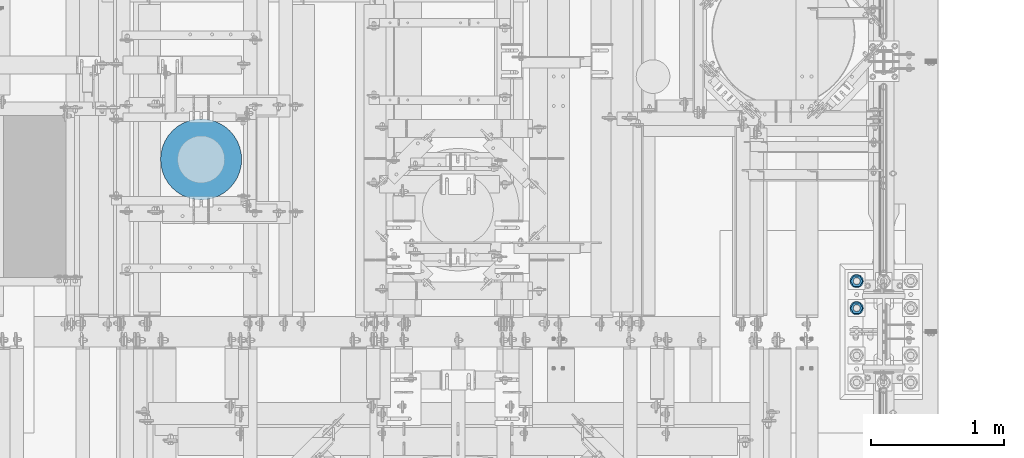
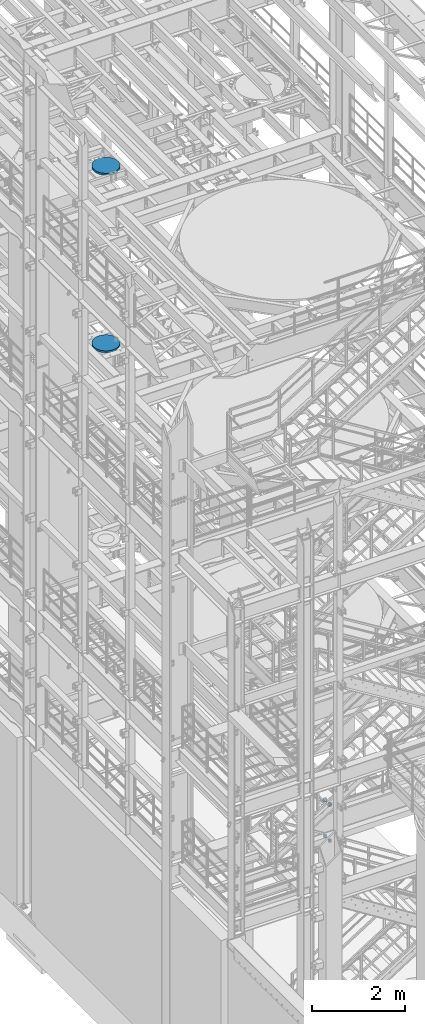
# One storey, part 839 of 1876: 8 columns, 3 elements without a shape of their own.
"""IFC2X3 building model written with IfcOpenShell, lengths in millimetres."""

from ifc_helpers import new_model, si_unit, frame, origin_with_axes, place, context, subcontext, project, spatial, faceted_brep, material, type_object, element, aggregate, save


model = new_model("IFC2X3")

# Units and contexts
model_context = context("Model", 3, precision=1e-05, world=origin_with_axes())
body_context = subcontext(model_context, "Body", "Model", "MODEL_VIEW")
ifc_project = project(units=[si_unit("LENGTHUNIT", "METRE", prefix="MILLI"), si_unit("AREAUNIT", "SQUARE_METRE"), si_unit("VOLUMEUNIT", "CUBIC_METRE"), si_unit("MASSUNIT", "GRAM", prefix="KILO"), si_unit("TIMEUNIT", "SECOND"), si_unit("PLANEANGLEUNIT", "RADIAN"), si_unit("SOLIDANGLEUNIT", "STERADIAN"), si_unit("THERMODYNAMICTEMPERATUREUNIT", "DEGREE_CELSIUS"), si_unit("LUMINOUSINTENSITYUNIT", "LUMEN")], contexts=[model_context])

# Site, building, storey
site_placement = place(None, origin_with_axes())
site = spatial("IfcSite", under=ifc_project, at=site_placement, CompositionType="ELEMENT")
building_placement = place(site_placement, origin_with_axes())
building = spatial("IfcBuilding", under=site, at=building_placement, Name="Undefined", CompositionType="ELEMENT")
storey_placement = place(building_placement, origin_with_axes())
storey = spatial("IfcBuildingStorey", under=building, at=storey_placement, Name="Undefined", CompositionType="ELEMENT", Elevation=0.0)

# Assembly, columns
assembly_1_placement = place(storey_placement, origin_with_axes())
assembly_1 = element("IfcElementAssembly", 1, at=assembly_1_placement, inside=storey, Name="TEMPLATE", AssemblyPlace="NOTDEFINED", PredefinedType="RIGID_FRAME")
ifc_material_1 = material(Name="STEEL/F436")
column_type_1 = type_object("IfcColumnType", Name="2_WASHER", PredefinedType="NOTDEFINED")
column_1_placement = place(assembly_1_placement, frame((7416.8, 1701.8, 119.0625), z_axis=(0.0, -1.0, 0.0), x_axis=(0.0, 0.0, -1.0)))
column_1 = element("IfcColumn", 2, at=column_1_placement, type_object=column_type_1, material=ifc_material_1, Name="WASHER", ObjectType="2_WASHER", context=body_context, shape_type="Brep", body=[
    faceted_brep([(0.0, -50.7999992370605, 9.09494701772928e-13), (0.0, -45.7692178020588, -22.0412936161442), (4.7625, -45.7692178020588, -22.0412936161442), (4.7625, -50.7999992370605, 9.09494701772928e-13), (0.0, -31.6732814587394, -39.7170387128856), (4.7625, -31.6732814587394, -39.7170387128856), (0.0, -11.3040632752118, -49.5263371950259), (4.7625, -11.3040632752118, -49.5263371950259), (0.0, 11.30406327521, -49.5263371950264), (4.7625, 11.30406327521, -49.5263371950264), (0.0, 31.6732814587385, -39.7170387128867), (4.7625, 31.6732814587385, -39.7170387128867), (0.0, 45.7692178020579, -22.041293616146), (4.7625, 45.7692178020579, -22.041293616146), (0.0, 50.7999992370605, -9.09494701772928e-13), (4.7625, 50.7999992370605, -9.09494701772928e-13), (0.0, 45.7692178020588, 22.0412936161442), (4.7625, 45.7692178020588, 22.0412936161442), (0.0, 31.6732814587394, 39.7170387128856), (4.7625, 31.6732814587394, 39.7170387128856), (0.0, 11.3040632752118, 49.5263371950259), (4.7625, 11.3040632752118, 49.5263371950259), (0.0, -11.30406327521, 49.5263371950264), (4.7625, -11.30406327521, 49.5263371950264), (0.0, -31.6732814587385, 39.7170387128867), (4.7625, -31.6732814587385, 39.7170387128867), (0.0, -45.7692178020579, 22.041293616146), (4.7625, -45.7692178020579, 22.041293616146), (0.0, 0.0, 26.9869995117188), (0.0, 11.7093983825444, 24.3146012721213), (4.7625, 11.7093983825444, 24.3146012721213), (4.7625, 0.0, 26.9869995117188), (0.0, 21.0996520289491, 16.8262864224157), (4.7625, 21.0996520289491, 16.8262864224157), (0.0, 26.3108629296712, 6.00524193584533), (4.7625, 26.3108629296712, 6.00524193584533), (0.0, 26.3108629296712, -6.00524193584533), (4.7625, 26.3108629296712, -6.00524193584533), (0.0, 21.0996520289491, -16.8262864224157), (4.7625, 21.0996520289491, -16.8262864224157), (0.0, 11.7093983825444, -24.3146012721213), (4.7625, 11.7093983825444, -24.3146012721213), (0.0, 0.0, -26.9869995117188), (4.7625, 0.0, -26.9869995117188), (0.0, -11.7093983825444, -24.3146012721213), (4.7625, -11.7093983825444, -24.3146012721213), (0.0, -21.0996520289491, -16.8262864224157), (4.7625, -21.0996520289491, -16.8262864224157), (0.0, -26.3108629296712, -6.00524193584533), (4.7625, -26.3108629296712, -6.00524193584533), (0.0, -26.3108629296712, 6.00524193584533), (4.7625, -26.3108629296712, 6.00524193584533), (0.0, -21.0996520289491, 16.8262864224157), (4.7625, -21.0996520289491, 16.8262864224157), (0.0, -11.7093983825444, 24.3146012721213), (4.7625, -11.7093983825444, 24.3146012721213)], [[[0, 1, 2, 3]], [[1, 4, 5, 2]], [[4, 6, 7, 5]], [[6, 8, 9, 7]], [[8, 10, 11, 9]], [[10, 12, 13, 11]], [[12, 14, 15, 13]], [[14, 16, 17, 15]], [[16, 18, 19, 17]], [[18, 20, 21, 19]], [[20, 22, 23, 21]], [[22, 24, 25, 23]], [[24, 26, 27, 25]], [[26, 0, 3, 27]], [[28, 29, 30, 31]], [[29, 32, 33, 30]], [[32, 34, 35, 33]], [[34, 36, 37, 35]], [[36, 38, 39, 37]], [[38, 40, 41, 39]], [[40, 42, 43, 41]], [[42, 44, 45, 43]], [[44, 46, 47, 45]], [[46, 48, 49, 47]], [[48, 50, 51, 49]], [[50, 52, 53, 51]], [[52, 54, 55, 53]], [[54, 28, 31, 55]], [[5, 7, 9, 11, 13, 15, 17, 19, 21, 23, 25, 27, 3, 2], [33, 35, 37, 39, 41, 43, 45, 47, 49, 51, 53, 55, 31, 30]], [[26, 24, 22, 20, 18, 16, 14, 12, 10, 8, 6, 4, 1, 0], [54, 52, 50, 48, 46, 44, 42, 40, 38, 36, 34, 32, 29, 28]]]),
])
column_2_placement = place(assembly_1_placement, frame((7416.8, 1905.0, 119.0625), z_axis=(0.0, -1.0, 0.0), x_axis=(0.0, 0.0, -1.0)))
column_2 = element("IfcColumn", 3, at=column_2_placement, type_object=column_type_1, material=ifc_material_1, Name="WASHER", ObjectType="2_WASHER", context=body_context, shape_type="Brep", body=[
    faceted_brep([(0.0, -50.7999992370605, 9.09494701772928e-13), (0.0, -45.7692178020588, -22.0412936161442), (4.7625, -45.7692178020588, -22.0412936161442), (4.7625, -50.7999992370605, 9.09494701772928e-13), (0.0, -31.6732814587394, -39.7170387128856), (4.7625, -31.6732814587394, -39.7170387128856), (0.0, -11.3040632752118, -49.5263371950259), (4.7625, -11.3040632752118, -49.5263371950259), (0.0, 11.30406327521, -49.5263371950264), (4.7625, 11.30406327521, -49.5263371950264), (0.0, 31.6732814587385, -39.7170387128867), (4.7625, 31.6732814587385, -39.7170387128867), (0.0, 45.7692178020579, -22.041293616146), (4.7625, 45.7692178020579, -22.041293616146), (0.0, 50.7999992370605, -9.09494701772928e-13), (4.7625, 50.7999992370605, -9.09494701772928e-13), (0.0, 45.7692178020588, 22.0412936161442), (4.7625, 45.7692178020588, 22.0412936161442), (0.0, 31.6732814587394, 39.7170387128856), (4.7625, 31.6732814587394, 39.7170387128856), (0.0, 11.3040632752118, 49.5263371950259), (4.7625, 11.3040632752118, 49.5263371950259), (0.0, -11.30406327521, 49.5263371950264), (4.7625, -11.30406327521, 49.5263371950264), (0.0, -31.6732814587385, 39.7170387128867), (4.7625, -31.6732814587385, 39.7170387128867), (0.0, -45.7692178020579, 22.041293616146), (4.7625, -45.7692178020579, 22.041293616146), (0.0, 0.0, 26.9869995117188), (0.0, 11.7093983825444, 24.3146012721213), (4.7625, 11.7093983825444, 24.3146012721213), (4.7625, 0.0, 26.9869995117188), (0.0, 21.0996520289491, 16.8262864224157), (4.7625, 21.0996520289491, 16.8262864224157), (0.0, 26.3108629296712, 6.00524193584533), (4.7625, 26.3108629296712, 6.00524193584533), (0.0, 26.3108629296712, -6.00524193584533), (4.7625, 26.3108629296712, -6.00524193584533), (0.0, 21.0996520289491, -16.8262864224157), (4.7625, 21.0996520289491, -16.8262864224157), (0.0, 11.7093983825444, -24.3146012721213), (4.7625, 11.7093983825444, -24.3146012721213), (0.0, 0.0, -26.9869995117188), (4.7625, 0.0, -26.9869995117188), (0.0, -11.7093983825444, -24.3146012721213), (4.7625, -11.7093983825444, -24.3146012721213), (0.0, -21.0996520289491, -16.8262864224157), (4.7625, -21.0996520289491, -16.8262864224157), (0.0, -26.3108629296712, -6.00524193584533), (4.7625, -26.3108629296712, -6.00524193584533), (0.0, -26.3108629296712, 6.00524193584533), (4.7625, -26.3108629296712, 6.00524193584533), (0.0, -21.0996520289491, 16.8262864224157), (4.7625, -21.0996520289491, 16.8262864224157), (0.0, -11.7093983825444, 24.3146012721213), (4.7625, -11.7093983825444, 24.3146012721213)], [[[0, 1, 2, 3]], [[1, 4, 5, 2]], [[4, 6, 7, 5]], [[6, 8, 9, 7]], [[8, 10, 11, 9]], [[10, 12, 13, 11]], [[12, 14, 15, 13]], [[14, 16, 17, 15]], [[16, 18, 19, 17]], [[18, 20, 21, 19]], [[20, 22, 23, 21]], [[22, 24, 25, 23]], [[24, 26, 27, 25]], [[26, 0, 3, 27]], [[28, 29, 30, 31]], [[29, 32, 33, 30]], [[32, 34, 35, 33]], [[34, 36, 37, 35]], [[36, 38, 39, 37]], [[38, 40, 41, 39]], [[40, 42, 43, 41]], [[42, 44, 45, 43]], [[44, 46, 47, 45]], [[46, 48, 49, 47]], [[48, 50, 51, 49]], [[50, 52, 53, 51]], [[52, 54, 55, 53]], [[54, 28, 31, 55]], [[5, 7, 9, 11, 13, 15, 17, 19, 21, 23, 25, 27, 3, 2], [33, 35, 37, 39, 41, 43, 45, 47, 49, 51, 53, 55, 31, 30]], [[26, 24, 22, 20, 18, 16, 14, 12, 10, 8, 6, 4, 1, 0], [54, 52, 50, 48, 46, 44, 42, 40, 38, 36, 34, 32, 29, 28]]]),
])

# Assembly, column
assembly_2_placement = place(storey_placement, origin_with_axes())
assembly_2 = element("IfcElementAssembly", 4, at=assembly_2_placement, inside=storey, Name="COLUMN", AssemblyPlace="NOTDEFINED", PredefinedType="REINFORCEMENT_UNIT")
ifc_material_2 = material(Name="CONCRETE/3000")
column_type_2 = type_object("IfcColumnType", PredefinedType="NOTDEFINED")
column_3_placement = place(assembly_2_placement, frame((2489.2, 2819.4, 17957.8), z_axis=(-1.0, 0.0, 0.0), x_axis=(0.0, 0.0, 1.0)))
column_3 = element("IfcColumn", 5, at=column_3_placement, type_object=column_type_2, material=ifc_material_2, Name="COLUMN", context=body_context, shape_type="Brep", body=[
    faceted_brep([(0.0, -304.8, 0.0), (0.0, -301.047406213398, -47.6812249442623), (50.7999999999993, -301.047406213398, -47.6812249442623), (50.7999999999993, -304.8, 0.0), (0.0, -289.882026166763, -94.1883798854842), (50.7999999999993, -289.882026166763, -94.1883798854842), (0.0, -271.578788572614, -138.376304320614), (50.7999999999993, -271.578788572614, -138.376304320614), (0.0, -246.588379885484, -179.156944898746), (50.7999999999993, -246.588379885484, -179.156944898746), (0.0, -215.52614690566, -215.52614690566), (50.7999999999993, -215.52614690566, -215.52614690566), (0.0, -179.156944898746, -246.588379885484), (50.7999999999993, -179.156944898746, -246.588379885484), (0.0, -138.376304320614, -271.578788572614), (50.7999999999993, -138.376304320614, -271.578788572614), (0.0, -94.1883798854838, -289.882026166763), (50.7999999999993, -94.1883798854838, -289.882026166763), (0.0, -47.6812249442623, -301.047406213398), (50.7999999999993, -47.6812249442623, -301.047406213398), (0.0, 0.0, -304.8), (50.7999999999993, 0.0, -304.8), (0.0, 47.6812249442623, -301.047406213398), (50.7999999999993, 47.6812249442623, -301.047406213398), (0.0, 94.1883798854842, -289.882026166763), (50.7999999999993, 94.1883798854842, -289.882026166763), (0.0, 138.376304320614, -271.578788572614), (50.7999999999993, 138.376304320614, -271.578788572614), (0.0, 179.156944898746, -246.588379885484), (50.7999999999993, 179.156944898746, -246.588379885484), (0.0, 215.52614690566, -215.52614690566), (50.7999999999993, 215.52614690566, -215.52614690566), (0.0, 246.588379885484, -179.156944898746), (50.7999999999993, 246.588379885484, -179.156944898746), (0.0, 271.578788572614, -138.376304320614), (50.7999999999993, 271.578788572614, -138.376304320614), (0.0, 289.882026166763, -94.1883798854838), (50.7999999999993, 289.882026166763, -94.1883798854838), (0.0, 301.047406213398, -47.6812249442623), (50.7999999999993, 301.047406213398, -47.6812249442623), (0.0, 304.8, 0.0), (50.7999999999993, 304.8, 0.0), (0.0, 301.047406213398, 47.6812249442623), (50.7999999999993, 301.047406213398, 47.6812249442623), (0.0, 289.882026166763, 94.1883798854842), (50.7999999999993, 289.882026166763, 94.1883798854842), (0.0, 271.578788572614, 138.376304320614), (50.7999999999993, 271.578788572614, 138.376304320614), (0.0, 246.588379885484, 179.156944898746), (50.7999999999993, 246.588379885484, 179.156944898746), (0.0, 215.52614690566, 215.52614690566), (50.7999999999993, 215.52614690566, 215.52614690566), (0.0, 179.156944898746, 246.588379885484), (50.7999999999993, 179.156944898746, 246.588379885484), (0.0, 138.376304320614, 271.578788572614), (50.7999999999993, 138.376304320614, 271.578788572614), (0.0, 94.1883798854838, 289.882026166763), (50.7999999999993, 94.1883798854838, 289.882026166763), (0.0, 47.6812249442623, 301.047406213398), (50.7999999999993, 47.6812249442623, 301.047406213398), (0.0, 0.0, 304.8), (50.7999999999993, 0.0, 304.8), (0.0, -47.6812249442623, 301.047406213398), (50.7999999999993, -47.6812249442623, 301.047406213398), (0.0, -94.1883798854838, 289.882026166763), (50.7999999999993, -94.1883798854838, 289.882026166763), (0.0, -138.376304320614, 271.578788572614), (50.7999999999993, -138.376304320614, 271.578788572614), (0.0, -179.156944898746, 246.588379885484), (50.7999999999993, -179.156944898746, 246.588379885484), (0.0, -215.52614690566, 215.52614690566), (50.7999999999993, -215.52614690566, 215.52614690566), (0.0, -246.588379885484, 179.156944898746), (50.7999999999993, -246.588379885484, 179.156944898746), (0.0, -271.578788572614, 138.376304320614), (50.7999999999993, -271.578788572614, 138.376304320614), (0.0, -289.882026166763, 94.1883798854838), (50.7999999999993, -289.882026166763, 94.1883798854838), (0.0, -301.047406213398, 47.6812249442623), (50.7999999999993, -301.047406213398, 47.6812249442623)], [[[0, 1, 2, 3]], [[1, 4, 5, 2]], [[4, 6, 7, 5]], [[6, 8, 9, 7]], [[8, 10, 11, 9]], [[10, 12, 13, 11]], [[12, 14, 15, 13]], [[14, 16, 17, 15]], [[16, 18, 19, 17]], [[18, 20, 21, 19]], [[20, 22, 23, 21]], [[22, 24, 25, 23]], [[24, 26, 27, 25]], [[26, 28, 29, 27]], [[28, 30, 31, 29]], [[30, 32, 33, 31]], [[32, 34, 35, 33]], [[34, 36, 37, 35]], [[36, 38, 39, 37]], [[38, 40, 41, 39]], [[40, 42, 43, 41]], [[42, 44, 45, 43]], [[44, 46, 47, 45]], [[46, 48, 49, 47]], [[48, 50, 51, 49]], [[50, 52, 53, 51]], [[52, 54, 55, 53]], [[54, 56, 57, 55]], [[56, 58, 59, 57]], [[58, 60, 61, 59]], [[60, 62, 63, 61]], [[62, 64, 65, 63]], [[64, 66, 67, 65]], [[66, 68, 69, 67]], [[68, 70, 71, 69]], [[70, 72, 73, 71]], [[72, 74, 75, 73]], [[74, 76, 77, 75]], [[76, 78, 79, 77]], [[78, 0, 3, 79]], [[5, 7, 9, 11, 13, 15, 17, 19, 21, 23, 25, 27, 29, 31, 33, 35, 37, 39, 41, 43, 45, 47, 49, 51, 53, 55, 57, 59, 61, 63, 65, 67, 69, 71, 73, 75, 77, 79, 3, 2]], [[78, 76, 74, 72, 70, 68, 66, 64, 62, 60, 58, 56, 54, 52, 50, 48, 46, 44, 42, 40, 38, 36, 34, 32, 30, 28, 26, 24, 22, 20, 18, 16, 14, 12, 10, 8, 6, 4, 1, 0]]]),
])
aggregate(assembly_2, [column_3])

assembly_3_placement = place(storey_placement, origin_with_axes())
assembly_3 = element("IfcElementAssembly", 6, at=assembly_3_placement, inside=storey, Name="COLUMN", AssemblyPlace="NOTDEFINED", PredefinedType="REINFORCEMENT_UNIT")
column_4_placement = place(assembly_3_placement, frame((2489.2, 2819.4, 13284.2), z_axis=(-1.0, 0.0, 0.0), x_axis=(0.0, 0.0, 1.0)))
column_4 = element("IfcColumn", 7, at=column_4_placement, type_object=column_type_2, material=ifc_material_2, Name="COLUMN", context=body_context, shape_type="Brep", body=[
    faceted_brep([(0.0, -304.8, 0.0), (0.0, -301.047406213398, -47.6812249442623), (50.7999999999993, -301.047406213398, -47.6812249442623), (50.7999999999993, -304.8, 0.0), (0.0, -289.882026166763, -94.1883798854842), (50.7999999999993, -289.882026166763, -94.1883798854842), (0.0, -271.578788572614, -138.376304320614), (50.7999999999993, -271.578788572614, -138.376304320614), (0.0, -246.588379885484, -179.156944898746), (50.7999999999993, -246.588379885484, -179.156944898746), (0.0, -215.52614690566, -215.52614690566), (50.7999999999993, -215.52614690566, -215.52614690566), (0.0, -179.156944898746, -246.588379885484), (50.7999999999993, -179.156944898746, -246.588379885484), (0.0, -138.376304320614, -271.578788572614), (50.7999999999993, -138.376304320614, -271.578788572614), (0.0, -94.1883798854838, -289.882026166763), (50.7999999999993, -94.1883798854838, -289.882026166763), (0.0, -47.6812249442623, -301.047406213398), (50.7999999999993, -47.6812249442623, -301.047406213398), (0.0, 0.0, -304.8), (50.7999999999993, 0.0, -304.8), (0.0, 47.6812249442623, -301.047406213398), (50.7999999999993, 47.6812249442623, -301.047406213398), (0.0, 94.1883798854842, -289.882026166763), (50.7999999999993, 94.1883798854842, -289.882026166763), (0.0, 138.376304320614, -271.578788572614), (50.7999999999993, 138.376304320614, -271.578788572614), (0.0, 179.156944898746, -246.588379885484), (50.7999999999993, 179.156944898746, -246.588379885484), (0.0, 215.52614690566, -215.52614690566), (50.7999999999993, 215.52614690566, -215.52614690566), (0.0, 246.588379885484, -179.156944898746), (50.7999999999993, 246.588379885484, -179.156944898746), (0.0, 271.578788572614, -138.376304320614), (50.7999999999993, 271.578788572614, -138.376304320614), (0.0, 289.882026166763, -94.1883798854838), (50.7999999999993, 289.882026166763, -94.1883798854838), (0.0, 301.047406213398, -47.6812249442623), (50.7999999999993, 301.047406213398, -47.6812249442623), (0.0, 304.8, 0.0), (50.7999999999993, 304.8, 0.0), (0.0, 301.047406213398, 47.6812249442623), (50.7999999999993, 301.047406213398, 47.6812249442623), (0.0, 289.882026166763, 94.1883798854842), (50.7999999999993, 289.882026166763, 94.1883798854842), (0.0, 271.578788572614, 138.376304320614), (50.7999999999993, 271.578788572614, 138.376304320614), (0.0, 246.588379885484, 179.156944898746), (50.7999999999993, 246.588379885484, 179.156944898746), (0.0, 215.52614690566, 215.52614690566), (50.7999999999993, 215.52614690566, 215.52614690566), (0.0, 179.156944898746, 246.588379885484), (50.7999999999993, 179.156944898746, 246.588379885484), (0.0, 138.376304320614, 271.578788572614), (50.7999999999993, 138.376304320614, 271.578788572614), (0.0, 94.1883798854838, 289.882026166763), (50.7999999999993, 94.1883798854838, 289.882026166763), (0.0, 47.6812249442623, 301.047406213398), (50.7999999999993, 47.6812249442623, 301.047406213398), (0.0, 0.0, 304.8), (50.7999999999993, 0.0, 304.8), (0.0, -47.6812249442623, 301.047406213398), (50.7999999999993, -47.6812249442623, 301.047406213398), (0.0, -94.1883798854838, 289.882026166763), (50.7999999999993, -94.1883798854838, 289.882026166763), (0.0, -138.376304320614, 271.578788572614), (50.7999999999993, -138.376304320614, 271.578788572614), (0.0, -179.156944898746, 246.588379885484), (50.7999999999993, -179.156944898746, 246.588379885484), (0.0, -215.52614690566, 215.52614690566), (50.7999999999993, -215.52614690566, 215.52614690566), (0.0, -246.588379885484, 179.156944898746), (50.7999999999993, -246.588379885484, 179.156944898746), (0.0, -271.578788572614, 138.376304320614), (50.7999999999993, -271.578788572614, 138.376304320614), (0.0, -289.882026166763, 94.1883798854838), (50.7999999999993, -289.882026166763, 94.1883798854838), (0.0, -301.047406213398, 47.6812249442623), (50.7999999999993, -301.047406213398, 47.6812249442623)], [[[0, 1, 2, 3]], [[1, 4, 5, 2]], [[4, 6, 7, 5]], [[6, 8, 9, 7]], [[8, 10, 11, 9]], [[10, 12, 13, 11]], [[12, 14, 15, 13]], [[14, 16, 17, 15]], [[16, 18, 19, 17]], [[18, 20, 21, 19]], [[20, 22, 23, 21]], [[22, 24, 25, 23]], [[24, 26, 27, 25]], [[26, 28, 29, 27]], [[28, 30, 31, 29]], [[30, 32, 33, 31]], [[32, 34, 35, 33]], [[34, 36, 37, 35]], [[36, 38, 39, 37]], [[38, 40, 41, 39]], [[40, 42, 43, 41]], [[42, 44, 45, 43]], [[44, 46, 47, 45]], [[46, 48, 49, 47]], [[48, 50, 51, 49]], [[50, 52, 53, 51]], [[52, 54, 55, 53]], [[54, 56, 57, 55]], [[56, 58, 59, 57]], [[58, 60, 61, 59]], [[60, 62, 63, 61]], [[62, 64, 65, 63]], [[64, 66, 67, 65]], [[66, 68, 69, 67]], [[68, 70, 71, 69]], [[70, 72, 73, 71]], [[72, 74, 75, 73]], [[74, 76, 77, 75]], [[76, 78, 79, 77]], [[78, 0, 3, 79]], [[5, 7, 9, 11, 13, 15, 17, 19, 21, 23, 25, 27, 29, 31, 33, 35, 37, 39, 41, 43, 45, 47, 49, 51, 53, 55, 57, 59, 61, 63, 65, 67, 69, 71, 73, 75, 77, 79, 3, 2]], [[78, 76, 74, 72, 70, 68, 66, 64, 62, 60, 58, 56, 54, 52, 50, 48, 46, 44, 42, 40, 38, 36, 34, 32, 30, 28, 26, 24, 22, 20, 18, 16, 14, 12, 10, 8, 6, 4, 1, 0]]]),
])
aggregate(assembly_3, [column_4])

# Column
ifc_material_3 = material(Name="STEEL/A563")
column_type_3 = type_object("IfcColumnType", Name="2_HEAVY_HEX_NUT", PredefinedType="NOTDEFINED")
column_5_placement = place(assembly_1_placement, frame((7416.8, 1701.8, 169.8625), z_axis=(0.0, -1.0, 0.0), x_axis=(0.0, 0.0, -1.0)))
column_5 = element("IfcColumn", 8, at=column_5_placement, type_object=column_type_3, material=ifc_material_3, Name="NUT", ObjectType="2_HEAVY_HEX_NUT", context=body_context, shape_type="Brep", body=[
    faceted_brep([(0.0, -46.0369987487793, 9.09494701772928e-13), (0.0, -23.0184993743896, -39.869213104248), (50.8, -23.0184993743896, -39.869213104248), (50.8, -46.0369987487793, 9.09494701772928e-13), (0.0, 23.0184993743896, -39.869213104248), (50.8, 23.0184993743896, -39.869213104248), (0.0, 46.0369987487793, -9.09494701772928e-13), (50.8, 46.0369987487793, -9.09494701772928e-13), (0.0, 23.0184993743896, 39.869213104248), (50.8, 23.0184993743896, 39.869213104248), (0.0, -23.0184993743896, 39.869213104248), (50.8, -23.0184993743896, 39.869213104248), (0.0, 0.0, 26.1940002441406), (0.0, 11.3650617044514, 23.5999013092769), (50.8, 11.3650617044513, 23.5999013092771), (50.8, 0.0, 26.1940002441406), (0.0, 20.4791109456437, 16.3316083006703), (50.8, 20.4791109456439, 16.3316083006703), (0.0, 25.5370200498346, 5.82867859874477), (50.8, 25.5370200498343, 5.82867859874455), (0.0, 25.5370200498346, -5.82867859874477), (50.8, 25.5370200498343, -5.82867859874455), (0.0, 20.4791109456437, -16.3316083006703), (50.8, 20.4791109456439, -16.3316083006703), (0.0, 11.3650617044514, -23.5999013092769), (50.8, 11.3650617044514, -23.5999013092771), (0.0, 0.0, -26.1940002441406), (50.8, 0.0, -26.1940002441406), (0.0, -11.3650617044514, -23.5999013092769), (50.8, -11.3650617044513, -23.5999013092771), (0.0, -20.4791109456437, -16.3316083006703), (50.8, -20.4791109456439, -16.3316083006703), (0.0, -25.5370200498346, -5.82867859874477), (50.8, -25.5370200498343, -5.82867859874455), (0.0, -25.5370200498346, 5.82867859874477), (50.8, -25.5370200498343, 5.82867859874455), (0.0, -20.4791109456437, 16.3316083006703), (50.8, -20.4791109456439, 16.3316083006703), (0.0, -11.3650617044514, 23.5999013092769), (50.8, -11.3650617044514, 23.5999013092771)], [[[0, 1, 2, 3]], [[1, 4, 5, 2]], [[4, 6, 7, 5]], [[6, 8, 9, 7]], [[8, 10, 11, 9]], [[10, 0, 3, 11]], [[12, 13, 14, 15]], [[13, 16, 17, 14]], [[16, 18, 19, 17]], [[18, 20, 21, 19]], [[20, 22, 23, 21]], [[22, 24, 25, 23]], [[24, 26, 27, 25]], [[26, 28, 29, 27]], [[28, 30, 31, 29]], [[30, 32, 33, 31]], [[32, 34, 35, 33]], [[34, 36, 37, 35]], [[36, 38, 39, 37]], [[38, 12, 15, 39]], [[5, 7, 9, 11, 3, 2], [17, 19, 21, 23, 25, 27, 29, 31, 33, 35, 37, 39, 15, 14]], [[10, 8, 6, 4, 1, 0], [38, 36, 34, 32, 30, 28, 26, 24, 22, 20, 18, 16, 13, 12]]]),
])

column_6_placement = place(assembly_1_placement, frame((7416.8, 1701.8, -793.75), z_axis=(0.0, -1.0, 0.0), x_axis=(0.0, 0.0, -1.0)))
column_6 = element("IfcColumn", 9, at=column_6_placement, type_object=column_type_3, material=ifc_material_3, Name="NUT", ObjectType="2_HEAVY_HEX_NUT", context=body_context, shape_type="Brep", body=[
    faceted_brep([(0.0, -46.0369987487793, 9.09494701772928e-13), (0.0, -23.0184993743896, -39.869213104248), (50.8, -23.0184993743896, -39.869213104248), (50.8, -46.0369987487793, 9.09494701772928e-13), (0.0, 23.0184993743896, -39.869213104248), (50.8, 23.0184993743896, -39.869213104248), (0.0, 46.0369987487793, -9.09494701772928e-13), (50.8, 46.0369987487793, -9.09494701772928e-13), (0.0, 23.0184993743896, 39.869213104248), (50.8, 23.0184993743896, 39.869213104248), (0.0, -23.0184993743896, 39.869213104248), (50.8, -23.0184993743896, 39.869213104248), (0.0, 0.0, 26.1940002441406), (0.0, 11.3650617044514, 23.5999013092769), (50.8, 11.3650617044513, 23.5999013092771), (50.8, 0.0, 26.1940002441406), (0.0, 20.4791109456437, 16.3316083006703), (50.8, 20.4791109456439, 16.3316083006703), (0.0, 25.5370200498346, 5.82867859874477), (50.8, 25.5370200498343, 5.82867859874455), (0.0, 25.5370200498346, -5.82867859874477), (50.8, 25.5370200498343, -5.82867859874455), (0.0, 20.4791109456437, -16.3316083006703), (50.8, 20.4791109456439, -16.3316083006703), (0.0, 11.3650617044514, -23.5999013092769), (50.8, 11.3650617044514, -23.5999013092771), (0.0, 0.0, -26.1940002441406), (50.8, 0.0, -26.1940002441406), (0.0, -11.3650617044514, -23.5999013092769), (50.8, -11.3650617044513, -23.5999013092771), (0.0, -20.4791109456437, -16.3316083006703), (50.8, -20.4791109456439, -16.3316083006703), (0.0, -25.5370200498346, -5.82867859874477), (50.8, -25.5370200498343, -5.82867859874455), (0.0, -25.5370200498346, 5.82867859874477), (50.8, -25.5370200498343, 5.82867859874455), (0.0, -20.4791109456437, 16.3316083006703), (50.8, -20.4791109456439, 16.3316083006703), (0.0, -11.3650617044514, 23.5999013092769), (50.8, -11.3650617044514, 23.5999013092771)], [[[0, 1, 2, 3]], [[1, 4, 5, 2]], [[4, 6, 7, 5]], [[6, 8, 9, 7]], [[8, 10, 11, 9]], [[10, 0, 3, 11]], [[12, 13, 14, 15]], [[13, 16, 17, 14]], [[16, 18, 19, 17]], [[18, 20, 21, 19]], [[20, 22, 23, 21]], [[22, 24, 25, 23]], [[24, 26, 27, 25]], [[26, 28, 29, 27]], [[28, 30, 31, 29]], [[30, 32, 33, 31]], [[32, 34, 35, 33]], [[34, 36, 37, 35]], [[36, 38, 39, 37]], [[38, 12, 15, 39]], [[5, 7, 9, 11, 3, 2], [17, 19, 21, 23, 25, 27, 29, 31, 33, 35, 37, 39, 15, 14]], [[10, 8, 6, 4, 1, 0], [38, 36, 34, 32, 30, 28, 26, 24, 22, 20, 18, 16, 13, 12]]]),
])

column_7_placement = place(assembly_1_placement, frame((7416.8, 1905.0, 169.8625), z_axis=(0.0, -1.0, 0.0), x_axis=(0.0, 0.0, -1.0)))
column_7 = element("IfcColumn", 10, at=column_7_placement, type_object=column_type_3, material=ifc_material_3, Name="NUT", ObjectType="2_HEAVY_HEX_NUT", context=body_context, shape_type="Brep", body=[
    faceted_brep([(0.0, -46.0369987487793, 9.09494701772928e-13), (0.0, -23.0184993743896, -39.869213104248), (50.8, -23.0184993743896, -39.869213104248), (50.8, -46.0369987487793, 9.09494701772928e-13), (0.0, 23.0184993743896, -39.869213104248), (50.8, 23.0184993743896, -39.869213104248), (0.0, 46.0369987487793, -9.09494701772928e-13), (50.8, 46.0369987487793, -9.09494701772928e-13), (0.0, 23.0184993743896, 39.869213104248), (50.8, 23.0184993743896, 39.869213104248), (0.0, -23.0184993743896, 39.869213104248), (50.8, -23.0184993743896, 39.869213104248), (0.0, 0.0, 26.1940002441406), (0.0, 11.3650617044514, 23.5999013092769), (50.8, 11.3650617044513, 23.5999013092771), (50.8, 0.0, 26.1940002441406), (0.0, 20.4791109456437, 16.3316083006703), (50.8, 20.4791109456439, 16.3316083006703), (0.0, 25.5370200498346, 5.82867859874477), (50.8, 25.5370200498343, 5.82867859874455), (0.0, 25.5370200498346, -5.82867859874477), (50.8, 25.5370200498343, -5.82867859874455), (0.0, 20.4791109456437, -16.3316083006703), (50.8, 20.4791109456439, -16.3316083006703), (0.0, 11.3650617044514, -23.5999013092769), (50.8, 11.3650617044514, -23.5999013092771), (0.0, 0.0, -26.1940002441406), (50.8, 0.0, -26.1940002441406), (0.0, -11.3650617044514, -23.5999013092769), (50.8, -11.3650617044513, -23.5999013092771), (0.0, -20.4791109456437, -16.3316083006703), (50.8, -20.4791109456439, -16.3316083006703), (0.0, -25.5370200498346, -5.82867859874477), (50.8, -25.5370200498343, -5.82867859874455), (0.0, -25.5370200498346, 5.82867859874477), (50.8, -25.5370200498343, 5.82867859874455), (0.0, -20.4791109456437, 16.3316083006703), (50.8, -20.4791109456439, 16.3316083006703), (0.0, -11.3650617044514, 23.5999013092769), (50.8, -11.3650617044514, 23.5999013092771)], [[[0, 1, 2, 3]], [[1, 4, 5, 2]], [[4, 6, 7, 5]], [[6, 8, 9, 7]], [[8, 10, 11, 9]], [[10, 0, 3, 11]], [[12, 13, 14, 15]], [[13, 16, 17, 14]], [[16, 18, 19, 17]], [[18, 20, 21, 19]], [[20, 22, 23, 21]], [[22, 24, 25, 23]], [[24, 26, 27, 25]], [[26, 28, 29, 27]], [[28, 30, 31, 29]], [[30, 32, 33, 31]], [[32, 34, 35, 33]], [[34, 36, 37, 35]], [[36, 38, 39, 37]], [[38, 12, 15, 39]], [[5, 7, 9, 11, 3, 2], [17, 19, 21, 23, 25, 27, 29, 31, 33, 35, 37, 39, 15, 14]], [[10, 8, 6, 4, 1, 0], [38, 36, 34, 32, 30, 28, 26, 24, 22, 20, 18, 16, 13, 12]]]),
])

column_8_placement = place(assembly_1_placement, frame((7416.8, 1905.0, -793.75), z_axis=(0.0, -1.0, 0.0), x_axis=(0.0, 0.0, -1.0)))
column_8 = element("IfcColumn", 11, at=column_8_placement, type_object=column_type_3, material=ifc_material_3, Name="NUT", ObjectType="2_HEAVY_HEX_NUT", context=body_context, shape_type="Brep", body=[
    faceted_brep([(0.0, -46.0369987487793, 9.09494701772928e-13), (0.0, -23.0184993743896, -39.869213104248), (50.8, -23.0184993743896, -39.869213104248), (50.8, -46.0369987487793, 9.09494701772928e-13), (0.0, 23.0184993743896, -39.869213104248), (50.8, 23.0184993743896, -39.869213104248), (0.0, 46.0369987487793, -9.09494701772928e-13), (50.8, 46.0369987487793, -9.09494701772928e-13), (0.0, 23.0184993743896, 39.869213104248), (50.8, 23.0184993743896, 39.869213104248), (0.0, -23.0184993743896, 39.869213104248), (50.8, -23.0184993743896, 39.869213104248), (0.0, 0.0, 26.1940002441406), (0.0, 11.3650617044514, 23.5999013092769), (50.8, 11.3650617044513, 23.5999013092771), (50.8, 0.0, 26.1940002441406), (0.0, 20.4791109456437, 16.3316083006703), (50.8, 20.4791109456439, 16.3316083006703), (0.0, 25.5370200498346, 5.82867859874477), (50.8, 25.5370200498343, 5.82867859874455), (0.0, 25.5370200498346, -5.82867859874477), (50.8, 25.5370200498343, -5.82867859874455), (0.0, 20.4791109456437, -16.3316083006703), (50.8, 20.4791109456439, -16.3316083006703), (0.0, 11.3650617044514, -23.5999013092769), (50.8, 11.3650617044514, -23.5999013092771), (0.0, 0.0, -26.1940002441406), (50.8, 0.0, -26.1940002441406), (0.0, -11.3650617044514, -23.5999013092769), (50.8, -11.3650617044513, -23.5999013092771), (0.0, -20.4791109456437, -16.3316083006703), (50.8, -20.4791109456439, -16.3316083006703), (0.0, -25.5370200498346, -5.82867859874477), (50.8, -25.5370200498343, -5.82867859874455), (0.0, -25.5370200498346, 5.82867859874477), (50.8, -25.5370200498343, 5.82867859874455), (0.0, -20.4791109456437, 16.3316083006703), (50.8, -20.4791109456439, 16.3316083006703), (0.0, -11.3650617044514, 23.5999013092769), (50.8, -11.3650617044514, 23.5999013092771)], [[[0, 1, 2, 3]], [[1, 4, 5, 2]], [[4, 6, 7, 5]], [[6, 8, 9, 7]], [[8, 10, 11, 9]], [[10, 0, 3, 11]], [[12, 13, 14, 15]], [[13, 16, 17, 14]], [[16, 18, 19, 17]], [[18, 20, 21, 19]], [[20, 22, 23, 21]], [[22, 24, 25, 23]], [[24, 26, 27, 25]], [[26, 28, 29, 27]], [[28, 30, 31, 29]], [[30, 32, 33, 31]], [[32, 34, 35, 33]], [[34, 36, 37, 35]], [[36, 38, 39, 37]], [[38, 12, 15, 39]], [[5, 7, 9, 11, 3, 2], [17, 19, 21, 23, 25, 27, 29, 31, 33, 35, 37, 39, 15, 14]], [[10, 8, 6, 4, 1, 0], [38, 36, 34, 32, 30, 28, 26, 24, 22, 20, 18, 16, 13, 12]]]),
])

aggregate(assembly_1, [column_5, column_1, column_6, column_7, column_2, column_8])

save(model, "model.ifc")
